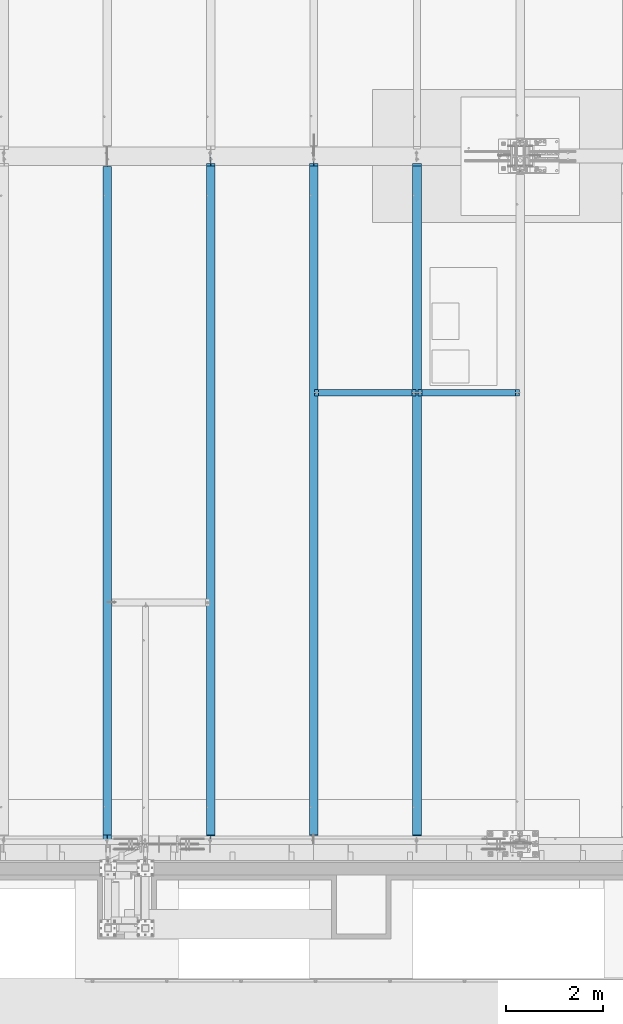
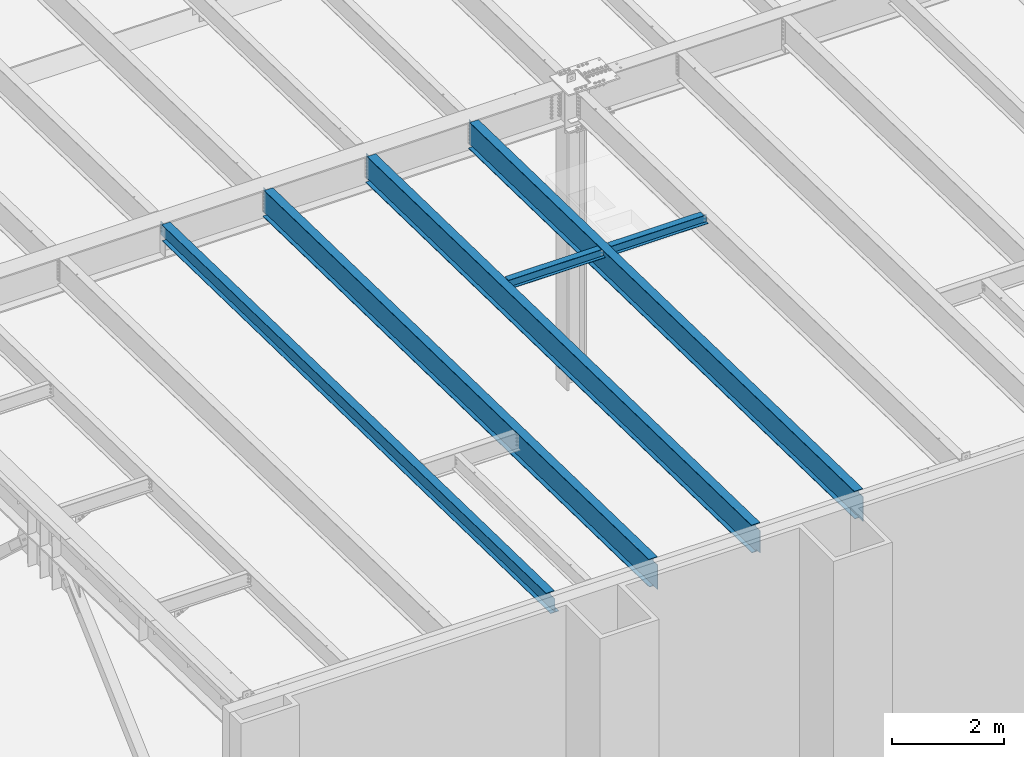
# One storey, part 1040 of 1763: 6 beams, 6 elements without a shape of their own.
"""IFC2X3 building model written with IfcOpenShell, lengths in millimetres."""

from ifc_helpers import new_model, si_unit, frame, origin_with_axes, place, context, subcontext, project, spatial, faceted_brep, material, type_object, element, aggregate, save


model = new_model("IFC2X3")

# Units and contexts
model_context = context("Model", 3, precision=1e-05, world=origin_with_axes())
body_context = subcontext(model_context, "Body", "Model", "MODEL_VIEW")
ifc_project = project(units=[si_unit("LENGTHUNIT", "METRE", prefix="MILLI"), si_unit("AREAUNIT", "SQUARE_METRE"), si_unit("VOLUMEUNIT", "CUBIC_METRE"), si_unit("MASSUNIT", "GRAM", prefix="KILO"), si_unit("TIMEUNIT", "SECOND"), si_unit("PLANEANGLEUNIT", "RADIAN"), si_unit("SOLIDANGLEUNIT", "STERADIAN"), si_unit("THERMODYNAMICTEMPERATUREUNIT", "DEGREE_CELSIUS"), si_unit("LUMINOUSINTENSITYUNIT", "LUMEN")], contexts=[model_context])

# Site, building, storey
site_placement = place(None, origin_with_axes())
site = spatial("IfcSite", under=ifc_project, at=site_placement, CompositionType="ELEMENT")
building_placement = place(site_placement, origin_with_axes())
building = spatial("IfcBuilding", under=site, at=building_placement, Name="Undefined", CompositionType="ELEMENT")
storey_placement = place(building_placement, origin_with_axes())
storey = spatial("IfcBuildingStorey", under=building, at=storey_placement, Name="Undefined", CompositionType="ELEMENT", Elevation=0.0)

# Assembly, beam
assembly_1_placement = place(storey_placement, origin_with_axes())
assembly_1 = element("IfcElementAssembly", 1, at=assembly_1_placement, inside=storey, Name="BEAM", AssemblyPlace="NOTDEFINED", PredefinedType="RIGID_FRAME")
ifc_material = material(Name="STEEL/A992")
beam_type_1 = type_object("IfcBeamType", Name="W8X18", PredefinedType="NOTDEFINED")
beam_1_placement = place(assembly_1_placement, frame((-74617.3801308412, -4419.6, 11907.1626782421), z_axis=(0.0, 0.0, 1.0), x_axis=(1.0, 0.0, 0.0)))
beam_1 = element("IfcBeam", 2, at=beam_1_placement, type_object=beam_type_1, material=ifc_material, Name="BEAM", ObjectType="W8X18", context=body_context, shape_type="Brep", body=[
    faceted_brep([(87.3125001907247, -3.17500000000018, 64.8275016680727), (87.3125001907247, 3.17500000000018, 64.8275016680727), (17.4624999999905, 3.17500000000018, 64.8275016680727), (17.4624999999905, -3.17500000000018, 64.8275016680727), (92.1725797087711, -3.17500000000018, 65.7942315906603), (92.1725797087711, 3.17500000000018, 65.7942315906603), (96.2927561769247, -3.17500000000018, 68.5472454911378), (96.2927561769247, 3.17500000000018, 68.5472454911378), (97.1527139098253, -3.17500000000018, 69.8342631898486), (97.1527139098253, 3.17500000000018, 69.8342631898486), (17.4624999999905, -3.17500000000018, -95.25), (17.4624999999905, -66.6750000000002, -95.25), (2108.88035714286, -66.6750000000002, -95.25), (2108.88035714286, -3.17500000000018, -95.25), (17.4624999999905, -66.6750000000002, -103.1875), (2108.88035714286, -66.6750000000002, -103.1875), (17.4624999999905, 66.6750000000002, -103.1875), (2108.88035714286, 66.6750000000002, -103.1875), (17.4624999999905, 66.6750000000002, -95.25), (2108.88035714286, 66.6750000000002, -95.25), (17.4624999999905, 3.17500000000018, -95.25), (2108.88035714286, 3.17500000000018, -95.25), (2108.88035714286, 3.17500000000018, 64.8275016741882), (2108.88035714286, -3.17500000000018, 64.8275016741882), (2039.03035695212, 3.17500000000018, 64.8275016741882), (2039.03035695212, -3.17500000000018, 64.8275016741882), (2034.17027743408, 3.17500000000018, 65.7942315967757), (2034.17027743408, -3.17500000000018, 65.7942315967757), (2030.05010096592, 3.17500000000018, 68.5472454972532), (2030.05010096592, -3.17500000000018, 68.5472454972532), (2029.19014323995, 3.17500000000018, 69.8342631855921), (2029.19014323995, -3.17500000000018, 69.8342631855921), (2028.4626040177, 3.17500000000018, 70.3203893521495), (2028.4626040177, -3.17500000000018, 70.3203893521495), (2025.70959011721, 3.17500000000018, 74.4405658203032), (2025.70959011721, -3.17500000000018, 74.4405658203032), (2024.74286019463, 3.17500000000018, 79.3006453383496), (2024.74286019463, -3.17500000000018, 79.3006453383496), (2024.74286019463, -66.6750000000002, 103.1875), (2024.74286019463, -66.6750000000002, 95.25), (2024.74286019463, -3.17500000000018, 95.25), (2024.74286019463, 3.17500000000018, 95.25), (2024.74286019463, 66.6750000000002, 95.25), (2024.74286019463, 66.6750000000002, 103.1875), (101.599996948244, 3.17500000000018, 95.25), (101.599996948244, 66.6750000000002, 95.25), (101.599996948244, 66.6750000000002, 103.1875), (101.599996948244, -66.6750000000002, 103.1875), (101.599996948244, -66.6750000000002, 95.25), (101.599996948244, -3.17500000000018, 95.25), (101.599996948244, 3.17500000000018, 79.3006453379949), (101.599996948244, -3.17500000000018, 79.3006453379949), (100.633267025656, 3.17500000000018, 74.4405658199485), (100.633267025656, -3.17500000000018, 74.4405658199485), (97.8802531251786, 3.17500000000018, 70.3203893517948), (97.8802531251786, -3.17500000000018, 70.3203893517948)], [[[0, 1, 2, 3]], [[4, 5, 1, 0]], [[6, 7, 5, 4]], [[8, 9, 7, 6]], [[10, 11, 12, 13]], [[11, 14, 15, 12]], [[14, 16, 17, 15]], [[16, 18, 19, 17]], [[18, 20, 21, 19]], [[13, 12, 15, 17, 19, 21, 22, 23]], [[23, 22, 24, 25]], [[25, 24, 26, 27]], [[27, 26, 28, 29]], [[29, 28, 30, 31]], [[32, 33, 31, 30]], [[33, 32, 34, 35]], [[35, 34, 36, 37]], [[38, 39, 40, 37, 36, 41, 42, 43]], [[42, 41, 44, 45]], [[43, 42, 45, 46]], [[38, 43, 46, 47]], [[39, 38, 47, 48]], [[40, 39, 48, 49]], [[47, 46, 45, 44, 50, 51, 49, 48]], [[51, 50, 52, 53]], [[53, 52, 54, 55]], [[4, 0, 3, 10, 13, 23, 25, 27, 29, 31, 33, 35, 37, 40, 49, 51, 53, 55, 8, 6]], [[20, 18, 16, 14, 11, 10, 3, 2]], [[54, 52, 50, 44, 41, 36, 34, 32, 30, 28, 26, 24, 22, 21, 20, 2, 1, 5, 7, 9]], [[55, 54, 9, 8]]]),
])
aggregate(assembly_1, [beam_1])

assembly_2_placement = place(storey_placement, origin_with_axes())
assembly_2 = element("IfcElementAssembly", 3, at=assembly_2_placement, inside=storey, Name="BEAM", AssemblyPlace="NOTDEFINED", PredefinedType="RIGID_FRAME")
beam_2_placement = place(assembly_2_placement, frame((-76743.7229879841, -4419.6, 11907.1626782421), z_axis=(0.0, 0.0, 1.0), x_axis=(1.0, 0.0, 0.0)))
beam_2 = element("IfcBeam", 4, at=beam_2_placement, type_object=beam_type_1, material=ifc_material, Name="BEAM", ObjectType="W8X18", context=body_context, shape_type="Brep", body=[
    faceted_brep([(2030.05010096592, -3.17500000000018, 68.5472454972532), (2030.05010096592, 3.17500000000018, 68.5472454972532), (2029.19014323995, 3.17500000000018, 69.8342631855921), (2029.19014323995, -3.17500000000018, 69.8342631855921), (2034.17027743408, -3.17500000000018, 65.7942315967757), (2034.17027743408, 3.17500000000018, 65.7942315967757), (2039.03035695212, -3.17500000000018, 64.8275016741882), (2039.03035695212, 3.17500000000018, 64.8275016741882), (2108.88035714286, -3.17500000000018, 64.8275016741882), (2108.88035714286, 3.17500000000018, 64.8275016741882), (2028.4626040177, -3.17500000000018, 70.3203893521495), (2028.4626040177, 3.17500000000018, 70.3203893521495), (2025.70959011721, 3.17500000000018, 74.4405658203032), (2025.70959011721, -3.17500000000018, 74.4405658203032), (2024.74286019463, 3.17500000000018, 79.3006453383496), (2024.74286019463, -3.17500000000018, 79.3006453383496), (2024.74286019463, -66.6750000000002, 103.1875), (2024.74286019463, -66.6750000000002, 95.25), (2024.74286019463, -3.17500000000018, 95.25), (2024.74286019463, 3.17500000000018, 95.25), (2024.74286019463, 66.6750000000002, 95.25), (2024.74286019463, 66.6750000000002, 103.1875), (101.599996948244, 3.17500000000018, 95.25), (101.599996948244, 66.6750000000002, 95.25), (101.599996948244, 66.6750000000002, 103.1875), (101.599996948244, -66.6750000000002, 103.1875), (101.599996948244, -66.6750000000002, 95.25), (101.599996948244, -3.17500000000018, 95.25), (101.599996948244, 3.17500000000018, 79.3006453379949), (101.599996948244, -3.17500000000018, 79.3006453379949), (100.633267025656, 3.17500000000018, 74.4405658199485), (100.633267025656, -3.17500000000018, 74.4405658199485), (97.8802531251786, 3.17500000000018, 70.3203893517948), (97.8802531251786, -3.17500000000018, 70.3203893517948), (97.1527139098253, 3.17500000000018, 69.8342631898486), (97.1527139098253, -3.17500000000018, 69.8342631898486), (96.2927561769247, 3.17500000000018, 68.5472454911378), (96.2927561769247, -3.17500000000018, 68.5472454911378), (92.1725797087711, 3.17500000000018, 65.7942315906603), (92.1725797087711, -3.17500000000018, 65.7942315906603), (87.3125001907247, 3.17500000000018, 64.8275016680727), (87.3125001907247, -3.17500000000018, 64.8275016680727), (17.4624999999905, 3.17500000000018, 64.8275016680727), (17.4624999999905, -3.17500000000018, 64.8275016680727), (17.4624999999905, 3.17500000000018, -95.25), (17.4624999999905, 66.6750000000002, -95.25), (17.4624999999905, 66.6750000000002, -103.1875), (17.4624999999905, -66.6750000000002, -103.1875), (17.4624999999905, -66.6750000000002, -95.25), (17.4624999999905, -3.17500000000018, -95.25), (2108.88035714286, 3.17500000000018, -95.25), (2108.88035714286, 66.6750000000002, -95.25), (2108.88035714286, 66.6750000000002, -103.1875), (2108.88035714286, -66.6750000000002, -103.1875), (2108.88035714286, -66.6750000000002, -95.25), (2108.88035714286, -3.17500000000018, -95.25)], [[[0, 1, 2, 3]], [[4, 5, 1, 0]], [[6, 7, 5, 4]], [[8, 9, 7, 6]], [[10, 11, 12, 13]], [[13, 12, 14, 15]], [[16, 17, 18, 15, 14, 19, 20, 21]], [[20, 19, 22, 23]], [[21, 20, 23, 24]], [[16, 21, 24, 25]], [[17, 16, 25, 26]], [[18, 17, 26, 27]], [[25, 24, 23, 22, 28, 29, 27, 26]], [[29, 28, 30, 31]], [[31, 30, 32, 33]], [[33, 32, 34, 35]], [[35, 34, 36, 37]], [[37, 36, 38, 39]], [[39, 38, 40, 41]], [[41, 40, 42, 43]], [[44, 45, 46, 47, 48, 49, 43, 42]], [[45, 44, 50, 51]], [[46, 45, 51, 52]], [[47, 46, 52, 53]], [[48, 47, 53, 54]], [[49, 48, 54, 55]], [[39, 41, 43, 49, 55, 8, 6, 4, 0, 3, 10, 13, 15, 18, 27, 29, 31, 33, 35, 37]], [[11, 10, 3, 2]], [[32, 30, 28, 22, 19, 14, 12, 11, 2, 1, 5, 7, 9, 50, 44, 42, 40, 38, 36, 34]], [[55, 54, 53, 52, 51, 50, 9, 8]]]),
])
aggregate(assembly_2, [beam_2])

assembly_3_placement = place(storey_placement, origin_with_axes())
assembly_3 = element("IfcElementAssembly", 5, at=assembly_3_placement, inside=storey, Name="BEAM", AssemblyPlace="NOTDEFINED", PredefinedType="RIGID_FRAME")
beam_type_2 = type_object("IfcBeamType", Name="W14X30", PredefinedType="NOTDEFINED")
beam_3_placement = place(assembly_3_placement, frame((-80996.4087022698, -13719.6830209329, 12028.5259948905), z_axis=(0.0, 0.0209013539966291, 0.999781542838788), x_axis=(0.0, 0.999781542776098, -0.0209013569953182)))
beam_3 = element("IfcBeam", 6, at=beam_3_placement, type_object=beam_type_2, material=ifc_material, Name="BEAM", ObjectType="W14X30", context=body_context, shape_type="Brep", body=[
    faceted_brep([(13959.8226386302, 3.17500000000291, -166.687500004733), (13959.8226103824, 3.1749548050575, -176.21250000474), (13959.8226188021, 85.7250000000058, -176.21250000474), (13959.8226470499, 85.7250000000058, -166.687500004733), (14162.8234865388, 3.17500000000291, -166.687500004798), (14163.0226154558, 3.17493408516748, -176.212500004805), (31.7803897484609, -3.17500000000291, -166.687500000144), (31.7803897484609, -85.7250000000058, -166.687500000144), (13959.8226149769, -85.7250000000058, -166.687500004733), (13959.8226233974, -3.17500000000291, -166.687500004733), (187.045633701837, 3.17500000000291, 166.687500000073), (187.045633701837, 85.7250000000058, 166.687500000073), (13966.172615604, 85.7250000000058, 166.687499995534), (13966.172615604, 3.17500000000291, 166.687499995534), (187.045633701842, -85.7250000000058, 176.212500000081), (187.045633701842, 85.7250000000058, 176.212500000081), (187.045633701824, 3.17500000000291, 131.502497673137), (187.045633701824, -3.17500000000291, 131.502497673137), (187.045633701837, -3.17500000000291, 166.687500000073), (187.045633701837, -85.7250000000058, 166.687500000073), (186.078903779235, 3.17500000000291, 126.642418155077), (186.078903779235, -3.17500000000291, 126.642418155077), (183.32588987875, 3.17500000000291, 122.522241686915), (183.32588987875, -3.17500000000291, 122.522241686915), (179.205713410583, 3.17500000000291, 119.769227786432), (179.205713410583, -3.17500000000291, 119.769227786432), (174.345633892526, 3.17500000000291, 118.802497863844), (174.345633892526, -3.17500000000291, 118.802497863844), (25.8119578229307, 3.17500000000291, 118.802497863891), (25.8119578229307, -3.17500000000291, 118.802497863891), (31.7803897484609, 3.17500000000291, -166.687500000144), (31.7803897484609, 85.7250000000058, -166.687500000144), (31.9795186654665, 85.7250000000058, -176.212500000151), (31.9795186654665, -85.7250000000058, -176.212500000151), (13959.8226157772, -85.7250000000058, -176.21250000474), (13959.8226241977, -3.17503907541686, -176.21250000474), (14162.8234865388, -3.17500000000291, -166.687500004798), (14163.0226154558, -3.17505980198621, -176.212500004805), (13974.0125358952, -3.17500000000291, 118.44172979983), (13969.8923594271, -3.17500000000291, 121.194743700313), (13967.1393455266, -3.17500000000291, 125.314920168477), (13966.172615604, -3.17500000000291, 130.174999686535), (13966.172615604, -3.17500000000291, 166.687499995534), (14161.9606094803, -3.17500000000291, -125.413213444972), (14156.882807184, -3.17500000000291, 117.47499987724), (13978.8726154133, -3.17500000000291, 117.474999877237), (13966.172615604, -85.7250000000058, 166.687499995534), (13966.172615604, -85.7250000000058, 176.212499995541), (13966.172615604, 85.7250000000058, 176.212499995541), (13966.172615604, 3.17500000000291, 130.174999686535), (13967.1393455266, 3.17500000000291, 125.314920168477), (13969.8923594271, 3.17500000000291, 121.194743700313), (13974.0125358952, 3.17500000000291, 118.44172979983), (13978.8726154133, 3.17500000000291, 117.474999877237), (14156.882807184, 3.17500000000291, 117.47499987724), (14161.9606235421, 3.17500000000291, -125.413886068391)], [[[0, 1, 2, 3]], [[4, 5, 1, 0]], [[6, 7, 8, 9]], [[10, 11, 12, 13]], [[14, 15, 11, 10, 16, 17, 18, 19]], [[17, 16, 20, 21]], [[21, 20, 22, 23]], [[23, 22, 24, 25]], [[25, 24, 26, 27]], [[27, 26, 28, 29]], [[30, 31, 32, 33, 7, 6, 29, 28]], [[7, 33, 34, 8]], [[8, 34, 35, 9]], [[36, 9, 35, 37]], [[38, 39, 40, 41, 42, 18, 17, 21, 23, 25, 27, 29, 6, 9, 36, 43, 44, 45]], [[19, 18, 42, 46]], [[14, 19, 46, 47]], [[15, 14, 47, 48]], [[11, 15, 48, 12]], [[47, 46, 42, 41, 49, 13, 12, 48]], [[40, 50, 49, 41]], [[39, 51, 50, 40]], [[38, 52, 51, 39]], [[45, 53, 52, 38]], [[44, 54, 53, 45]], [[55, 4, 0, 30, 28, 26, 24, 22, 20, 16, 10, 13, 49, 50, 51, 52, 53, 54]], [[31, 30, 0, 3]], [[32, 31, 3, 2]], [[37, 35, 34, 33, 32, 2, 1, 5]], [[55, 54, 44, 43, 36, 37, 5, 4]]]),
])
aggregate(assembly_3, [beam_3])

assembly_4_placement = place(storey_placement, origin_with_axes())
assembly_4 = element("IfcElementAssembly", 7, at=assembly_4_placement, inside=storey, Name="BEAM", AssemblyPlace="NOTDEFINED", PredefinedType="RIGID_FRAME")
beam_type_3 = type_object("IfcBeamType", Name="W24X55", PredefinedType="NOTDEFINED")
beam_4_placement = place(assembly_4_placement, frame((-74617.3801308412, -13722.2711313756, 11904.7280453544), z_axis=(0.0, 0.0209013539966291, 0.999781542838788), x_axis=(0.0, 0.999781542776098, -0.0209013569953182)))
beam_4 = element("IfcBeam", 8, at=beam_4_placement, type_object=beam_type_3, material=ifc_material, Name="BEAM", ObjectType="W24X55", context=body_context, shape_type="Brep", body=[
    faceted_brep([(163.919115448763, -4.76249999999709, -287.337500000287), (164.18462067144, -4.76200008392334, -300.037500000297), (183.361759226002, -4.76239140644611, -300.037500000302), (183.361759226023, -4.76249999999709, -287.337500000292), (183.36176814427, -88.8999999999942, -287.337500000292), (183.361768144267, -88.8999999999942, -300.037500000302), (14034.9273989147, 5.06262332902406, -287.337500005337), (14034.9273989147, 5.06237371187308, -300.037500004868), (14034.9273925426, 88.8999999999942, -300.037500004868), (14034.9273925426, 88.8999999999942, -287.337500004856), (183.361749302438, 88.8999999999942, -300.037500000302), (183.361749302443, 88.8999999999942, -287.337500000292), (183.361758221019, 4.76261468007579, -300.037500000304), (183.361758221041, 4.76239139326208, -287.337500002202), (164.18462067144, 4.76299991607084, -300.037500000297), (163.919115448763, 4.76249999999709, -287.337500000287), (37.1568705442241, 4.76299991607084, -300.037500000257), (36.8913653215495, 4.76250000000073, -287.337500000245), (183.361748773876, 4.76250000000073, 287.337500000169), (183.361748773876, 88.9000000000015, 287.337500000169), (13971.4274064739, 88.8999999999942, 287.337499995627), (13971.4274064739, 4.76249999999709, 287.337499995627), (14167.9344621119, 4.76249999999709, -287.3375000049), (36.0948805793596, 4.76249999999709, -249.238979286023), (25.8065222748755, 4.76249999999709, 242.887500000506), (170.661748964563, 4.76249999999709, 242.887500000461), (175.521828482621, 4.76249999999709, 243.854229923048), (179.642004950787, 4.76249999999709, 246.607243823531), (182.395018851274, 4.76249999999709, 250.727420291694), (183.361748773865, 4.76249999999709, 255.58749980975), (13971.4274064739, 4.76250977152085, 248.977497550664), (13972.3941363965, 4.7625093152019, 244.117418032611), (13975.147150297, 4.76250892841199, 239.997241564446), (13979.2673267651, 4.76250866999908, 237.244227663961), (13984.1274062832, 4.76250857934065, 236.27749774137), (14156.9878072637, 4.76249999999709, 236.277497741372), (14167.9344621119, 5.06263343806495, -287.3375000049), (14168.1999673346, 5.06238384118478, -300.037500004912), (14156.9878072637, -4.76249999999709, 236.277497741372), (14167.9344621119, -4.76249999999709, -287.3375000049), (14167.9344621119, -5.06236354894645, -287.3375000049), (14168.1999673346, -5.06261314581207, -300.037500004912), (14034.927399722, -5.06237365734705, -287.337500004856), (14034.927399722, -5.06262327449804, -300.037500004866), (14034.9274060935, -88.8999999999942, -287.337500004856), (14034.9274060935, -88.8999999999942, -300.037500004868), (37.1568705442241, -4.76200008392334, -300.037500000257), (36.8913653215495, -4.76250000000073, -287.337500000245), (36.0948840789624, -4.76249999999709, -249.239146683703), (25.8065222748755, -4.76249999999709, 242.887500000506), (152.834272402093, -4.76249999999709, 242.887500000465), (170.661748964563, -4.76249999999709, 242.887500000461), (175.521828482621, -4.76249999999709, 243.854229923048), (179.642004950787, -4.76249999999709, 246.607243823531), (182.395018851274, -4.76249999999709, 250.727420291694), (183.361748773865, -4.76249999999709, 255.58749980975), (183.361748773879, -88.9000000000015, 300.03750000018), (183.361748773879, 88.9000000000015, 300.03750000018), (183.361748773876, -4.76250000000073, 287.337500000169), (183.361748773876, -88.9000000000015, 287.337500000169), (13971.4274064739, -4.76249999999709, 287.337499995627), (13971.4274064739, -88.8999999999942, 287.337499995627), (13971.4274064739, -88.8999999999942, 300.037499995638), (13971.4274064739, 88.8999999999942, 300.037499995638), (13971.4274064739, -4.76249999999709, 248.977497550664), (13972.3941363965, -4.76249999999709, 244.117418032611), (13975.147150297, -4.76249999999709, 239.997241564446), (13979.2673267651, -4.76249999999709, 237.244227663961), (13984.1274062832, -4.76249999999709, 236.27749774137)], [[[0, 1, 2, 3]], [[4, 3, 2, 5]], [[6, 7, 8, 9]], [[10, 11, 9, 8]], [[11, 10, 12, 13]], [[13, 12, 14, 15]], [[16, 17, 15, 14]], [[18, 19, 20, 21]], [[22, 13, 15, 17, 23, 24, 25, 26, 27, 28, 29, 18, 21, 30, 31, 32, 33, 34, 35]], [[9, 11, 13, 22, 36, 6]], [[37, 7, 6, 36]], [[22, 35, 38, 39, 40, 41, 37, 36]], [[41, 40, 42, 43]], [[44, 45, 43, 42]], [[45, 44, 4, 5]], [[1, 46, 16, 14, 12, 10, 8, 7, 37, 41, 43, 45, 5, 2]], [[1, 0, 47, 46]], [[48, 49, 24, 23, 17, 16, 46, 47]], [[50, 51, 25, 24, 49]], [[52, 26, 25, 51]], [[53, 27, 26, 52]], [[54, 28, 27, 53]], [[55, 29, 28, 54]], [[56, 57, 19, 18, 29, 55, 58, 59]], [[59, 58, 60, 61]], [[56, 59, 61, 62]], [[57, 56, 62, 63]], [[19, 57, 63, 20]], [[62, 61, 60, 64, 30, 21, 20, 63]], [[65, 31, 30, 64]], [[66, 32, 31, 65]], [[67, 33, 32, 66]], [[68, 34, 33, 67]], [[38, 35, 34, 68]], [[67, 66, 65, 64, 60, 58, 55, 54, 53, 52, 51, 50, 49, 48, 47, 0, 3, 39, 38, 68]], [[44, 42, 40, 39, 3, 4]]]),
])
aggregate(assembly_4, [beam_4])

assembly_5_placement = place(storey_placement, origin_with_axes())
assembly_5 = element("IfcElementAssembly", 9, at=assembly_5_placement, inside=storey, Name="BEAM", AssemblyPlace="NOTDEFINED", PredefinedType="RIGID_FRAME")
beam_5_placement = place(assembly_5_placement, frame((-76743.7229879841, -13722.2711313756, 11904.7280453544), z_axis=(0.0, 0.0209013539966291, 0.999781542838788), x_axis=(0.0, 0.999781542776098, -0.0209013569953182)))
beam_5 = element("IfcBeam", 10, at=beam_5_placement, type_object=beam_type_3, material=ifc_material, Name="BEAM", ObjectType="W24X55", context=body_context, shape_type="Brep", body=[
    faceted_brep([(14034.9273989147, 5.06262332902406, -287.337500005337), (14034.9273989147, 5.06237371187308, -300.037500004868), (14034.9273925426, 88.8999999999942, -300.037500004868), (14034.9273925426, 88.8999999999942, -287.337500004856), (14168.1999673346, 5.06238384118478, -300.037500004912), (14167.9344621119, 5.06263343806495, -287.3375000049), (189.63430965953, 4.76249999999709, 287.337500000165), (189.63430965953, 88.8999999999942, 287.337500000165), (13971.4274064739, 88.8999999999942, 287.337499995627), (13971.4274064739, 4.76249999999709, 287.337499995627), (14167.9344621119, 4.76249999999709, -287.3375000049), (189.634309659354, 4.76249999999709, -287.337500000294), (189.634309659363, 4.76249999999709, -255.847499810227), (188.667579736773, 4.76249999999709, -250.987420292167), (185.91456583629, 4.76249999999709, -246.867243824003), (181.794389368128, 4.76249999999709, -244.114229923518), (176.934309850072, 4.76249999999709, -243.147500000925), (35.9675325821936, 4.76249999999709, -243.14750000088), (25.811957859527, 4.76249999999709, 242.627497864287), (176.93430985022, 4.76249999999709, 242.627497864238), (181.794389368277, 4.76249999999709, 243.594227786825), (185.914565836441, 4.76249999999709, 246.34724168731), (188.66757973693, 4.76249999999709, 250.467418155475), (189.634309659519, 4.76249999999709, 255.32749767353), (13971.4274064739, 4.76250977152085, 248.977497550664), (13972.3941363965, 4.7625093152019, 244.117418032611), (13975.147150297, 4.76250892841199, 239.997241564446), (13979.2673267651, 4.76250866999908, 237.244227663961), (13984.1274062832, 4.76250857934065, 236.27749774137), (14156.9878072637, 4.76249999999709, 236.277497741372), (188.667579736773, -4.76249999999709, -250.987420292167), (189.634309659363, -4.76249999999709, -255.847499810227), (185.91456583629, -4.76249999999709, -246.867243824003), (181.794389368128, -4.76249999999709, -244.114229923518), (176.934309850072, -4.76249999999709, -243.147500000925), (35.9675325821936, -4.76249999999709, -243.14750000088), (25.811957859527, -4.76249999999709, 242.627497864287), (176.93430985022, -4.76249999999709, 242.627497864238), (181.794389368277, -4.76249999999709, 243.594227786825), (185.914565836441, -4.76249999999709, 246.34724168731), (188.66757973693, -4.76249999999709, 250.467418155475), (189.634309659519, -4.76249999999709, 255.32749767353), (189.634309659536, -88.8999999999942, 300.037500000177), (189.634309659536, 88.8999999999942, 300.037500000177), (189.63430965953, -4.76249999999709, 287.337500000165), (189.63430965953, -88.8999999999942, 287.337500000165), (13971.4274064739, -4.76249999999709, 287.337499995627), (13971.4274064739, -88.8999999999942, 287.337499995627), (13971.4274064739, -88.8999999999942, 300.037499995638), (13971.4274064739, 88.8999999999942, 300.037499995638), (13971.4274064739, -4.76249999999709, 248.977497550664), (13972.3941363965, -4.76249999999709, 244.117418032611), (13975.147150297, -4.76249999999709, 239.997241564446), (13979.2673267651, -4.76249999999709, 237.244227663961), (13984.1274062832, -4.76249999999709, 236.27749774137), (14156.9878072637, -4.76249999999709, 236.277497741372), (189.634309659354, -4.76249999999709, -287.337500000294), (14167.9344621119, -4.76249999999709, -287.3375000049), (189.634309659354, -88.8999999999942, -287.337500000294), (14034.9274060935, -88.8999999999942, -287.337500004856), (14034.927399722, -5.06237365734705, -287.337500004856), (14167.9344621119, -5.06236354894645, -287.3375000049), (189.634309659354, 88.8999999999942, -287.337500000294), (189.634309659348, 88.8999999999942, -300.037500000304), (189.634309659348, -88.8999999999942, -300.037500000304), (14034.9274060935, -88.8999999999942, -300.037500004868), (14034.927399722, -5.06262327449804, -300.037500004866), (14168.1999673346, -5.06261314581207, -300.037500004912)], [[[0, 1, 2, 3]], [[4, 1, 0, 5]], [[6, 7, 8, 9]], [[10, 11, 12, 13, 14, 15, 16, 17, 18, 19, 20, 21, 22, 23, 6, 9, 24, 25, 26, 27, 28, 29]], [[30, 13, 12, 31]], [[32, 14, 13, 30]], [[33, 15, 14, 32]], [[34, 16, 15, 33]], [[35, 17, 16, 34]], [[36, 18, 17, 35]], [[37, 19, 18, 36]], [[38, 20, 19, 37]], [[39, 21, 20, 38]], [[40, 22, 21, 39]], [[41, 23, 22, 40]], [[42, 43, 7, 6, 23, 41, 44, 45]], [[45, 44, 46, 47]], [[42, 45, 47, 48]], [[43, 42, 48, 49]], [[7, 43, 49, 8]], [[48, 47, 46, 50, 24, 9, 8, 49]], [[51, 25, 24, 50]], [[52, 26, 25, 51]], [[53, 27, 26, 52]], [[54, 28, 27, 53]], [[55, 29, 28, 54]], [[53, 52, 51, 50, 46, 44, 41, 40, 39, 38, 37, 36, 35, 34, 33, 32, 30, 31, 56, 57, 55, 54]], [[57, 56, 58, 59, 60, 61]], [[31, 12, 11, 62, 63, 64, 58, 56]], [[58, 64, 65, 59]], [[59, 65, 66, 60]], [[67, 61, 60, 66]], [[10, 29, 55, 57, 61, 67, 4, 5]], [[3, 62, 11, 10, 5, 0]], [[63, 62, 3, 2]], [[67, 66, 65, 64, 63, 2, 1, 4]]]),
])
aggregate(assembly_5, [beam_5])

assembly_6_placement = place(storey_placement, origin_with_axes())
assembly_6 = element("IfcElementAssembly", 11, at=assembly_6_placement, inside=storey, Name="BEAM", AssemblyPlace="NOTDEFINED", PredefinedType="RIGID_FRAME")
beam_6_placement = place(assembly_6_placement, frame((-78870.0658451269, -13722.2711313756, 11904.7280453544), z_axis=(0.0, 0.0209013539966291, 0.999781542838788), x_axis=(0.0, 0.999781542776098, -0.0209013569953182)))
beam_6 = element("IfcBeam", 12, at=beam_6_placement, type_object=beam_type_3, material=ifc_material, Name="BEAM", ObjectType="W24X55", context=body_context, shape_type="Brep", body=[
    faceted_brep([(163.919115448763, -4.76249999999709, -287.337500000287), (164.18462067144, -4.76200008392334, -300.037500000297), (183.361759226002, -4.76239140644611, -300.037500000302), (183.361759226023, -4.76249999999709, -287.337500000292), (183.36176814427, -88.8999999999942, -287.337500000292), (183.361768144267, -88.8999999999942, -300.037500000302), (14168.1999673346, 5.06250000001455, -300.037500004912), (14068.1661142181, 5.06250000001455, -300.037500004879), (14067.9006089955, 5.06250000001455, -287.337500005347), (14167.9344621119, 5.06250000001455, -287.3375000049), (14034.9273925426, 88.8999999999942, -287.337500004856), (183.361749302443, 88.8999999999942, -287.337500000292), (183.361758221041, 4.76239139326208, -287.337500002202), (14167.9344621119, 4.76249999999709, -287.3375000049), (14034.9273989147, 5.06262332902406, -287.337500005337), (14034.9273989147, 5.06237371187308, -300.037500004868), (14034.9273925426, 88.8999999999942, -300.037500004868), (183.361749302438, 88.8999999999942, -300.037500000302), (183.361758221019, 4.76261468007579, -300.037500000304), (164.18462067144, 4.76299991607084, -300.037500000297), (163.919115448763, 4.76249999999709, -287.337500000287), (37.1568705442241, 4.76299991607084, -300.037500000257), (36.8913653215495, 4.76250000000073, -287.337500000245), (183.361748773876, 4.76250000000073, 287.337500000169), (183.361748773876, 88.9000000000015, 287.337500000169), (13971.4274064739, 88.8999999999942, 287.337499995627), (13971.4274064739, 4.76249999999709, 287.337499995627), (36.0948805793596, 4.76249999999709, -249.238979286023), (25.8065222748755, 4.76249999999709, 242.887500000506), (170.661748964563, 4.76249999999709, 242.887500000461), (175.521828482621, 4.76249999999709, 243.854229923048), (179.642004950787, 4.76249999999709, 246.607243823531), (182.395018851274, 4.76249999999709, 250.727420291694), (183.361748773865, 4.76249999999709, 255.58749980975), (13971.4274064739, 4.76250977152085, 248.977497550664), (13972.3941363965, 4.7625093152019, 244.117418032611), (13975.147150297, 4.76250892841199, 239.997241564446), (13979.2673267651, 4.76250866999908, 237.244227663961), (13984.1274062832, 4.76250857934065, 236.27749774137), (14156.9878072637, 4.76249999999709, 236.277497741372), (14156.9878072637, -4.76249999999709, 236.277497741372), (14167.9344621119, -4.76249999999709, -287.3375000049), (14167.9344621119, -5.06236354894645, -287.3375000049), (14168.1999673346, -5.06261314581207, -300.037500004912), (14034.927399722, -5.06237365734705, -287.337500004856), (14034.927399722, -5.06262327449804, -300.037500004866), (14034.9274060935, -88.8999999999942, -287.337500004856), (14034.9274060935, -88.8999999999942, -300.037500004868), (37.1568705442241, -4.76200008392334, -300.037500000257), (36.8913653215495, -4.76250000000073, -287.337500000245), (36.0948840789624, -4.76249999999709, -249.239146683703), (25.8065222748755, -4.76249999999709, 242.887500000506), (152.834272402093, -4.76249999999709, 242.887500000465), (170.661748964563, -4.76249999999709, 242.887500000461), (175.521828482621, -4.76249999999709, 243.854229923048), (179.642004950787, -4.76249999999709, 246.607243823531), (182.395018851274, -4.76249999999709, 250.727420291694), (183.361748773865, -4.76249999999709, 255.58749980975), (183.361748773879, -88.9000000000015, 300.03750000018), (183.361748773879, 88.9000000000015, 300.03750000018), (183.361748773876, -4.76250000000073, 287.337500000169), (183.361748773876, -88.9000000000015, 287.337500000169), (13971.4274064739, -4.76249999999709, 287.337499995627), (13971.4274064739, -88.8999999999942, 287.337499995627), (13971.4274064739, -88.8999999999942, 300.037499995638), (13971.4274064739, 88.8999999999942, 300.037499995638), (13971.4274064739, -4.76249999999709, 248.977497550664), (13972.3941363965, -4.76249999999709, 244.117418032611), (13975.147150297, -4.76249999999709, 239.997241564446), (13979.2673267651, -4.76249999999709, 237.244227663961), (13984.1274062832, -4.76249999999709, 236.27749774137)], [[[0, 1, 2, 3]], [[4, 3, 2, 5]], [[6, 7, 8, 9]], [[10, 11, 12, 13, 9, 8, 14]], [[7, 15, 14, 8]], [[14, 15, 16, 10]], [[17, 11, 10, 16]], [[11, 17, 18, 12]], [[12, 18, 19, 20]], [[21, 22, 20, 19]], [[23, 24, 25, 26]], [[13, 12, 20, 22, 27, 28, 29, 30, 31, 32, 33, 23, 26, 34, 35, 36, 37, 38, 39]], [[6, 9, 13, 39, 40, 41, 42, 43]], [[43, 42, 44, 45]], [[46, 47, 45, 44]], [[47, 46, 4, 5]], [[1, 48, 21, 19, 18, 17, 16, 15, 7, 6, 43, 45, 47, 5, 2]], [[1, 0, 49, 48]], [[50, 51, 28, 27, 22, 21, 48, 49]], [[52, 53, 29, 28, 51]], [[54, 30, 29, 53]], [[55, 31, 30, 54]], [[56, 32, 31, 55]], [[57, 33, 32, 56]], [[58, 59, 24, 23, 33, 57, 60, 61]], [[61, 60, 62, 63]], [[58, 61, 63, 64]], [[59, 58, 64, 65]], [[24, 59, 65, 25]], [[64, 63, 62, 66, 34, 26, 25, 65]], [[67, 35, 34, 66]], [[68, 36, 35, 67]], [[69, 37, 36, 68]], [[70, 38, 37, 69]], [[40, 39, 38, 70]], [[69, 68, 67, 66, 62, 60, 57, 56, 55, 54, 53, 52, 51, 50, 49, 0, 3, 41, 40, 70]], [[46, 44, 42, 41, 3, 4]]]),
])
aggregate(assembly_6, [beam_6])

save(model, "model.ifc")
